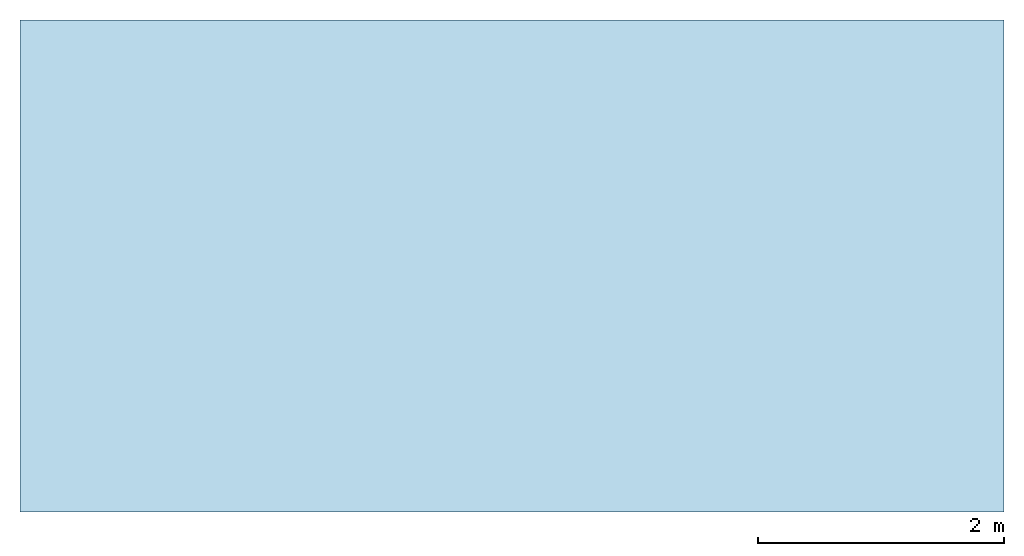
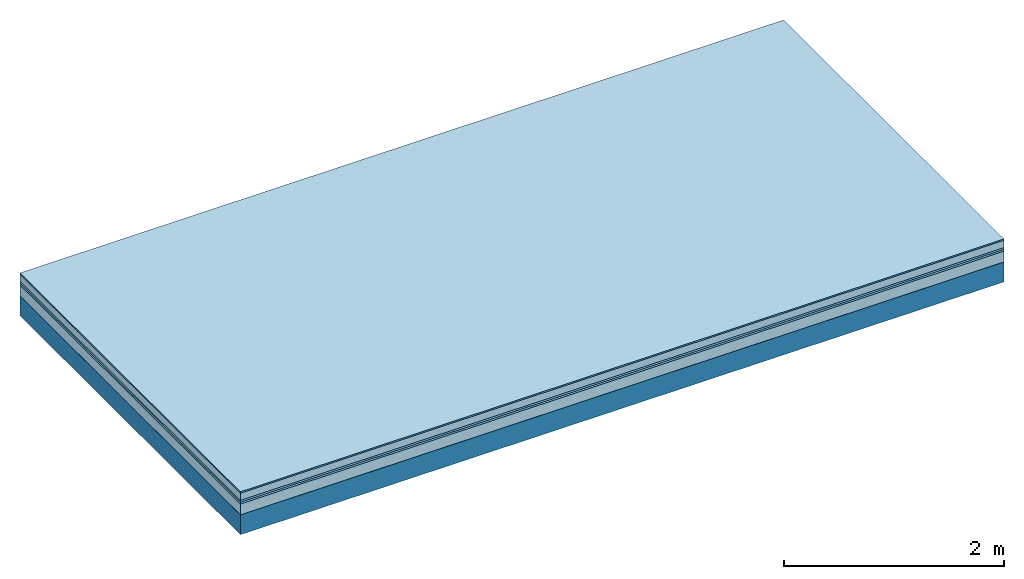
# One storey: 6 plates, 1 member, 1 element without a shape of its own.
"""IFC4 building model written with IfcOpenShell, lengths in metres."""

import ifcopenshell
import ifcopenshell.guid

model = None  # the IFC model being written
_history = None  # IfcOwnerHistory: only IFC2X3 demands one
_inside = {}  # id of a spatial element -> (the spatial element, [elements in it])
_under = {}  # id of a project, library or spatial element -> (it, [spatial elements below it])
_declared = {}  # id of a project -> (the project, [libraries it declares])
_typed = {}  # id of a type object -> (the type object, [elements of that type])
_made_of = {}  # id of a material, layer set ... -> (it, [elements and type objects made of it])


def new_model(schema):
    """Start an empty IFC model of exactly this schema.

    Asked for "IFC4X3", IfcOpenShell would pick the latest addendum, in which some entities
    have other attributes; the version numbers below select the first issue.
    IFC2X3 requires an IfcOwnerHistory on every rooted entity: one is made here for all.
    """
    global model, _history
    if schema == "IFC4X3":
        model = ifcopenshell.file(schema_version=(4, 3, 0, 0))
    else:
        model = ifcopenshell.file(schema=schema)
    _inside.clear()
    _under.clear()
    _declared.clear()
    _typed.clear()
    _made_of.clear()
    _history = None
    if model.schema == "IFC2X3":
        org = make("IfcOrganization", Name="unknown")
        user = make(
            "IfcPersonAndOrganization",
            ThePerson=make("IfcPerson", FamilyName="unknown"),
            TheOrganization=org,
        )
        app = make(
            "IfcApplication",
            ApplicationDeveloper=org,
            Version="unknown",
            ApplicationFullName="unknown",
            ApplicationIdentifier="unknown",
        )
        _history = make(
            "IfcOwnerHistory",
            OwningUser=user,
            OwningApplication=app,
            ChangeAction="ADDED",
            CreationDate=0,
        )
    return model


def make(cls, **values):
    """One entity of the class cls with the attributes given. An attribute that is None is left unset."""
    return model.create_entity(
        cls, **{name: value for name, value in values.items() if value is not None}
    )


def rooted(cls, **values):
    """An entity with a GlobalId (a new one), such as an element, a storey or a relation."""
    return make(cls, GlobalId=ifcopenshell.guid.new(), OwnerHistory=_history, **values)


def si_unit(unit_type, name, prefix=None):
    """IfcSIUnit, for example si_unit("LENGTHUNIT", "METRE", prefix="MILLI")."""
    return make("IfcSIUnit", UnitType=unit_type, Prefix=prefix, Name=name)


def derived_unit(unit_type, elements):
    """IfcDerivedUnit: a product of units, each with its exponent."""
    return make(
        "IfcDerivedUnit",
        Elements=[
            make("IfcDerivedUnitElement", Unit=unit, Exponent=power)
            for unit, power in elements
        ],
        UnitType=unit_type,
    )


def assignment(units):
    """IfcUnitAssignment: the units of a project."""
    return None if units is None else make("IfcUnitAssignment", Units=units)


def point(xyz):
    """IfcCartesianPoint."""
    return None if xyz is None else make("IfcCartesianPoint", Coordinates=xyz)


def direction(xyz):
    """IfcDirection."""
    return None if xyz is None else make("IfcDirection", DirectionRatios=xyz)


def frame(location, z_axis=None, x_axis=None):
    """IfcAxis2Placement3D, a coordinate frame: its origin and axes. An axis left out is left unset."""
    return make(
        "IfcAxis2Placement3D",
        Location=point(location),
        Axis=direction(z_axis),
        RefDirection=direction(x_axis),
    )


def frame_2d(location, x_axis=None):
    """IfcAxis2Placement2D, a coordinate frame in the plane: its origin and x axis."""
    return make(
        "IfcAxis2Placement2D", Location=point(location), RefDirection=direction(x_axis)
    )


def origin():
    """The frame at (0, 0, 0) with its axes left unset."""
    return frame((0.0, 0.0, 0.0))


def origin_with_axes():
    """The frame at (0, 0, 0) with the z axis (0, 0, 1) and the x axis (1, 0, 0) written out."""
    return frame((0.0, 0.0, 0.0), z_axis=(0.0, 0.0, 1.0), x_axis=(1.0, 0.0, 0.0))


def place(relative_to, where):
    """IfcLocalPlacement: puts the frame where relative to a parent placement (None: the world)."""
    return make(
        "IfcLocalPlacement", PlacementRelTo=relative_to, RelativePlacement=where
    )


def context(
    kind, dimensions, precision=None, world=None, true_north=None, identifier=None
):
    """IfcGeometricRepresentationContext, for example the 3D "Model" context."""
    return make(
        "IfcGeometricRepresentationContext",
        ContextIdentifier=identifier,
        ContextType=kind,
        CoordinateSpaceDimension=dimensions,
        Precision=precision,
        WorldCoordinateSystem=world,
        TrueNorth=true_north,
    )


def project(units=None, contexts=None):
    """IfcProject with its units and contexts."""
    return rooted(
        "IfcProject",
        Name="project",
        RepresentationContexts=contexts,
        UnitsInContext=assignment(units),
    )


def spatial(cls, under=None, at=None, **own):
    """A site, building, storey or space (cls), placed at a placement, below another one or the project."""
    s = rooted(cls, ObjectPlacement=at, **own)
    if under is not None:
        _under.setdefault(under.id(), (under, []))[1].append(s)
    return s


def profile(cls, at=None, kind="AREA", **sizes):
    """A parametric profile (cls). Its sizes go by their IFC names, for example OverallWidth=200.0."""
    return make(cls, ProfileType=kind, Position=at, **sizes)


def rectangle(**sizes):
    """IfcRectangleProfileDef."""
    return profile("IfcRectangleProfileDef", **sizes)


def extrude(swept, where, along, depth):
    """IfcExtrudedAreaSolid: the profile swept, set in the frame where, extruded along a direction by depth."""
    return make(
        "IfcExtrudedAreaSolid",
        SweptArea=swept,
        Position=where,
        ExtrudedDirection=direction(along),
        Depth=depth,
    )


def shape(context_of_items, identifier, shape_type, items):
    """IfcShapeRepresentation: the items that make up one representation, for example the "Body"."""
    return make(
        "IfcShapeRepresentation",
        ContextOfItems=context_of_items,
        RepresentationIdentifier=identifier,
        RepresentationType=shape_type,
        Items=items,
    )


def material(Name=None, Category=None):
    """IfcMaterial."""
    return make("IfcMaterial", Name=Name, Category=Category)


def layer(
    of_material, thickness, ventilated=None, Name=None, Category=None, Priority=None
):
    """IfcMaterialLayer: one layer of a wall or slab, of a material (None: an air gap)."""
    return make(
        "IfcMaterialLayer",
        Material=of_material,
        LayerThickness=thickness,
        IsVentilated=ventilated,
        Name=Name,
        Category=Category,
        Priority=Priority,
    )


def layer_set(layers, Name=None):
    """IfcMaterialLayerSet."""
    return make("IfcMaterialLayerSet", MaterialLayers=layers, LayerSetName=Name)


def made_of(thing, what):
    """Note that an element or type object is made of a material, layer set ...; save() writes the relation."""
    if what is not None:
        _made_of.setdefault(what.id(), (what, []))[1].append(thing)
    return thing


def type_object(cls, material=None, **own):
    """A type object (cls), such as IfcWallType, which elements share."""
    return made_of(rooted(cls, **own), material)


def element(
    cls,
    number,
    at=None,
    inside=None,
    cuts=None,
    type_object=None,
    material=None,
    context=None,
    identifier="Body",
    shape_type=None,
    held_by="IfcProductDefinitionShape",
    body=None,
    shapes=None,
    **own,
):
    """One element of the class cls, such as IfcWall. Its Tag is "e" and its number.

    at: its placement. inside: the storey or other place that contains it. cuts: it is an
    opening in that element (IfcRelVoidsElement). A single representation is given by context,
    identifier, shape_type and body (its items); several are given by shapes. held_by: the class
    of the entity that holds the representations. save() writes the other relations.
    """
    e = rooted(cls, Tag="e%d" % number, ObjectPlacement=at, **own)
    if body is not None:
        shapes = [shape(context, identifier, shape_type, body)]
    if shapes is not None:
        e.Representation = make(held_by, Representations=shapes)
    if inside is not None:
        _inside.setdefault(inside.id(), (inside, []))[1].append(e)
    if cuts is not None:
        rooted(
            "IfcRelVoidsElement", RelatingBuildingElement=cuts, RelatedOpeningElement=e
        )
    if type_object is not None:
        _typed.setdefault(type_object.id(), (type_object, []))[1].append(e)
    return made_of(e, material)


def aggregate(whole, parts):
    """IfcRelAggregates: a whole, such as a stair, and the parts it consists of."""
    return rooted("IfcRelAggregates", RelatingObject=whole, RelatedObjects=parts)


def save(model, path):
    """Write the relations noted so far, then the file.

    IfcRelAggregates (storeys below a building ...), IfcRelContainedInSpatialStructure (elements
    in a storey), IfcRelDefinesByType, IfcRelAssociatesMaterial and IfcRelDeclares: one each for
    every whole, place, type object, material and project.
    """
    for whole, parts in _under.values():
        aggregate(whole, parts)
    for where, things in _inside.values():
        rooted(
            "IfcRelContainedInSpatialStructure",
            RelatedElements=things,
            RelatingStructure=where,
        )
    for kind, things in _typed.values():
        rooted("IfcRelDefinesByType", RelatedObjects=things, RelatingType=kind)
    for what, things in _made_of.values():
        rooted("IfcRelAssociatesMaterial", RelatedObjects=things, RelatingMaterial=what)
    for by, libraries in _declared.values():
        rooted("IfcRelDeclares", RelatingContext=by, RelatedDefinitions=libraries)
    model.write(path)


model = new_model("IFC4")

# Units and contexts
plan_context = context("Plan", 3, precision=1e-05, world=origin(), true_north=direction((0.0, 1.0)))
model_context = context("Model", 3, precision=1e-05, world=origin(), true_north=direction((0.0, 1.0)))
ifc_project = project(units=[si_unit("LENGTHUNIT", "METRE"), derived_unit("SOUNDPRESSUREUNIT", [(si_unit("PRESSUREUNIT", "PASCAL", prefix="MICRO"), 0)]), si_unit("ENERGYUNIT", "JOULE", prefix="MEGA"), si_unit("MASSUNIT", "GRAM", prefix="KILO"), derived_unit("THERMALTRANSMITTANCEUNIT", [(si_unit("POWERUNIT", "WATT"), 1), (si_unit("AREAUNIT", "SQUARE_METRE"), -1), (si_unit("THERMODYNAMICTEMPERATUREUNIT", "KELVIN"), -1)]), derived_unit("AREADENSITYUNIT", [(si_unit("MASSUNIT", "GRAM", prefix="KILO"), 1), (si_unit("AREAUNIT", "SQUARE_METRE"), -1)]), derived_unit("USERDEFINED", [(si_unit("ENERGYUNIT", "JOULE", prefix="MEGA"), 1), (si_unit("AREAUNIT", "SQUARE_METRE"), -1)])], contexts=[plan_context, model_context])

# Site, building, storey
site = spatial("IfcSite", under=ifc_project)
building_placement = place(None, origin())
building = spatial("IfcBuilding", under=site, at=building_placement)
storey_placement = place(building_placement, origin())
storey = spatial("IfcBuildingStorey", under=building, at=storey_placement)

# Slab, member, plates
ifc_material_1 = material(Category="11.013")
ifc_layer_1 = layer(ifc_material_1, 0.015, Name="Flooring")
ifc_material_2 = material(Name="Cement screed", Category="04.006")
ifc_layer_2 = layer(ifc_material_2, 0.08, Name="On-material")
ifc_material_3 = material(Name="Wood fiber generic product", Category="10.009")
ifc_layer_3 = layer(ifc_material_3, 0.02, Name="Impact sound insulation")
ifc_material_4 = material()
ifc_layer_4 = layer(ifc_material_4, 0.02, Name="Additional insulation")
ifc_material_5 = material(Category="03.011")
ifc_layer_5 = layer(ifc_material_5, 0.12, Name="on Supporting structure")
ifc_material_6 = material(Name="protection", Category="09.007")
ifc_layer_6 = layer(ifc_material_6, 0.0005, Name="Sub-floor")
ifc_material_7 = material(Name="no composite action")
ifc_layer_7 = layer(ifc_material_7, 0.0, Name="Bond")
ifc_layer_8 = layer(None, 0.22, Name="Supporting structure")
ifc_layer_set = layer_set([ifc_layer_1, ifc_layer_2, ifc_layer_3, ifc_layer_4, ifc_layer_5, ifc_layer_6, ifc_layer_7, ifc_layer_8])
slab_type = type_object("IfcSlabType", Name="A2083", PredefinedType="NOTDEFINED", material=ifc_layer_set)
slab_placement = place(None, frame((0.0, 0.0, 0.0), z_axis=(0.0, 0.0, -1.0), x_axis=(1.0, 0.0, 0.0)))
slab = element("IfcSlab", 1, at=slab_placement, inside=storey, type_object=slab_type, material=ifc_layer_set, Name="Slab #1")
ifc_material_8 = material(Name="Solid timber panel")
member_placement = place(slab_placement, origin())
member = element("IfcMember", 2, at=member_placement, material=ifc_material_8, Name="Supporting structure", context=plan_context, shape_type="SweptSolid", body=[
    extrude(rectangle(XDim=1.0, YDim=0.22, at=frame_2d((0.5, 0.11), x_axis=(1.0, 0.0))), frame((0.0, 4.0, 0.2555), z_axis=(0.0, -1.0, 0.0), x_axis=(1.0, 0.0, 0.0)), (0.0, 0.0, 1.0), 4.0),
    extrude(rectangle(XDim=1.0, YDim=0.22, at=frame_2d((0.5, 0.11), x_axis=(1.0, 0.0))), frame((1.0, 4.0, 0.2555), z_axis=(0.0, -1.0, 0.0), x_axis=(1.0, 0.0, 0.0)), (0.0, 0.0, 1.0), 4.0),
    extrude(rectangle(XDim=1.0, YDim=0.22, at=frame_2d((0.5, 0.11), x_axis=(1.0, 0.0))), frame((2.0, 4.0, 0.2555), z_axis=(0.0, -1.0, 0.0), x_axis=(1.0, 0.0, 0.0)), (0.0, 0.0, 1.0), 4.0),
    extrude(rectangle(XDim=1.0, YDim=0.22, at=frame_2d((0.5, 0.11), x_axis=(1.0, 0.0))), frame((3.0, 4.0, 0.2555), z_axis=(0.0, -1.0, 0.0), x_axis=(1.0, 0.0, 0.0)), (0.0, 0.0, 1.0), 4.0),
    extrude(rectangle(XDim=1.0, YDim=0.22, at=frame_2d((0.5, 0.11), x_axis=(1.0, 0.0))), frame((4.0, 4.0, 0.2555), z_axis=(0.0, -1.0, 0.0), x_axis=(1.0, 0.0, 0.0)), (0.0, 0.0, 1.0), 4.0),
    extrude(rectangle(XDim=1.0, YDim=0.22, at=frame_2d((0.5, 0.11), x_axis=(1.0, 0.0))), frame((5.0, 4.0, 0.2555), z_axis=(0.0, -1.0, 0.0), x_axis=(1.0, 0.0, 0.0)), (0.0, 0.0, 1.0), 4.0),
    extrude(rectangle(XDim=1.0, YDim=0.22, at=frame_2d((0.5, 0.11), x_axis=(1.0, 0.0))), frame((6.0, 4.0, 0.2555), z_axis=(0.0, -1.0, 0.0), x_axis=(1.0, 0.0, 0.0)), (0.0, 0.0, 1.0), 4.0),
    extrude(rectangle(XDim=1.0, YDim=0.22, at=frame_2d((0.5, 0.11), x_axis=(1.0, 0.0))), frame((7.0, 4.0, 0.2555), z_axis=(0.0, -1.0, 0.0), x_axis=(1.0, 0.0, 0.0)), (0.0, 0.0, 1.0), 4.0),
])
plate_1_placement = place(slab_placement, origin())
plate_1 = element("IfcPlate", 3, at=plate_1_placement, material=ifc_material_1, Name="Flooring", context=plan_context, shape_type="SweptSolid", body=[
    extrude(rectangle(XDim=8.0, YDim=4.0, at=frame_2d((4.0, 2.0), x_axis=(1.0, 0.0))), origin_with_axes(), (0.0, 0.0, 1.0), 0.015),
])
plate_2_placement = place(slab_placement, origin())
plate_2 = element("IfcPlate", 4, at=plate_2_placement, material=ifc_material_2, Name="On-material", context=plan_context, shape_type="SweptSolid", body=[
    extrude(rectangle(XDim=8.0, YDim=4.0, at=frame_2d((4.0, 2.0), x_axis=(1.0, 0.0))), frame((0.0, 0.0, 0.015), z_axis=(0.0, 0.0, 1.0), x_axis=(1.0, 0.0, 0.0)), (0.0, 0.0, 1.0), 0.08),
])
plate_3_placement = place(slab_placement, origin())
plate_3 = element("IfcPlate", 5, at=plate_3_placement, material=ifc_material_3, Name="Impact sound insulation", context=plan_context, shape_type="SweptSolid", body=[
    extrude(rectangle(XDim=8.0, YDim=4.0, at=frame_2d((4.0, 2.0), x_axis=(1.0, 0.0))), frame((0.0, 0.0, 0.095), z_axis=(0.0, 0.0, 1.0), x_axis=(1.0, 0.0, 0.0)), (0.0, 0.0, 1.0), 0.02),
])
plate_4_placement = place(slab_placement, origin())
plate_4 = element("IfcPlate", 6, at=plate_4_placement, material=ifc_material_4, Name="Additional insulation", context=plan_context, shape_type="SweptSolid", body=[
    extrude(rectangle(XDim=8.0, YDim=4.0, at=frame_2d((4.0, 2.0), x_axis=(1.0, 0.0))), frame((0.0, 0.0, 0.115), z_axis=(0.0, 0.0, 1.0), x_axis=(1.0, 0.0, 0.0)), (0.0, 0.0, 1.0), 0.02),
])
plate_5_placement = place(slab_placement, origin())
plate_5 = element("IfcPlate", 7, at=plate_5_placement, material=ifc_material_5, Name="on Supporting structure", context=plan_context, shape_type="SweptSolid", body=[
    extrude(rectangle(XDim=8.0, YDim=4.0, at=frame_2d((4.0, 2.0), x_axis=(1.0, 0.0))), frame((0.0, 0.0, 0.135), z_axis=(0.0, 0.0, 1.0), x_axis=(1.0, 0.0, 0.0)), (0.0, 0.0, 1.0), 0.12),
])
plate_6_placement = place(slab_placement, origin())
plate_6 = element("IfcPlate", 8, at=plate_6_placement, material=ifc_material_6, Name="Sub-floor", context=plan_context, shape_type="SweptSolid", body=[
    extrude(rectangle(XDim=8.0, YDim=4.0, at=frame_2d((4.0, 2.0), x_axis=(1.0, 0.0))), frame((0.0, 0.0, 0.255), z_axis=(0.0, 0.0, 1.0), x_axis=(1.0, 0.0, 0.0)), (0.0, 0.0, 1.0), 0.0005),
])
aggregate(slab, [plate_1, plate_2, plate_3, plate_4, plate_5, plate_6, member])

save(model, "model.ifc")
